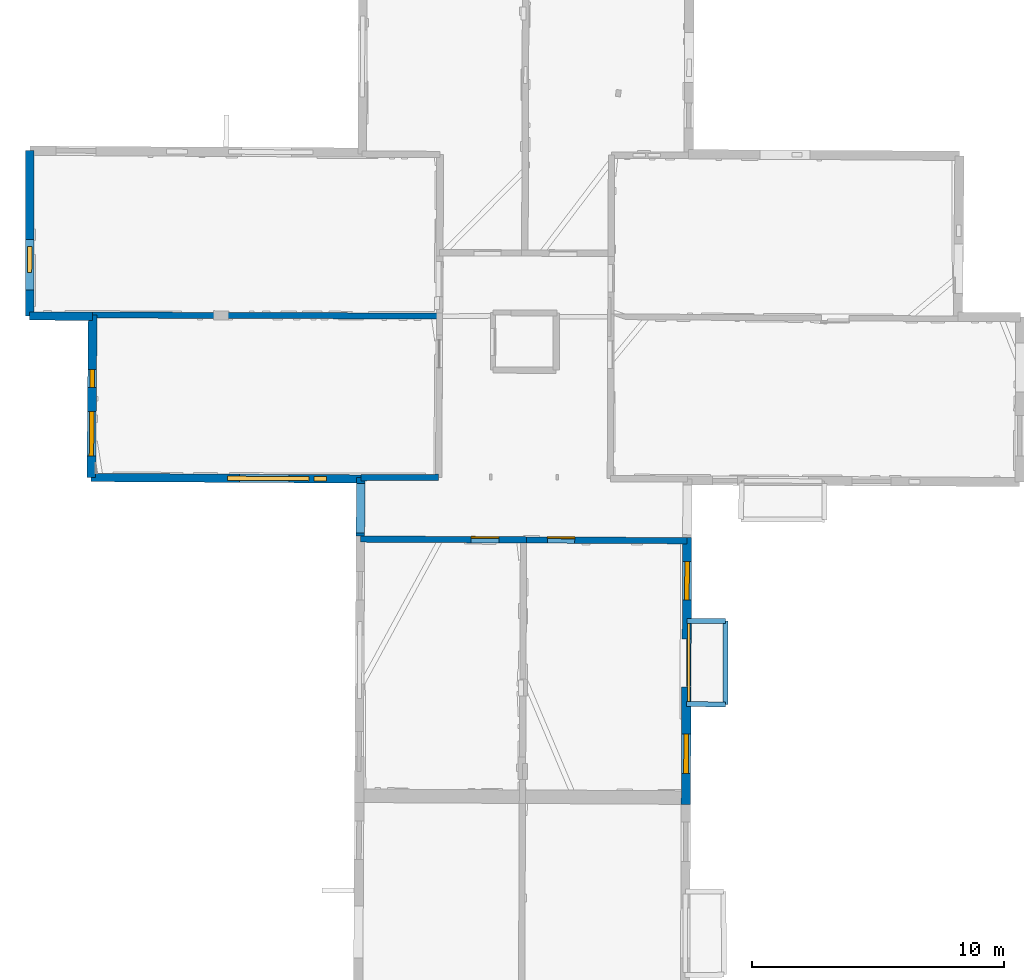
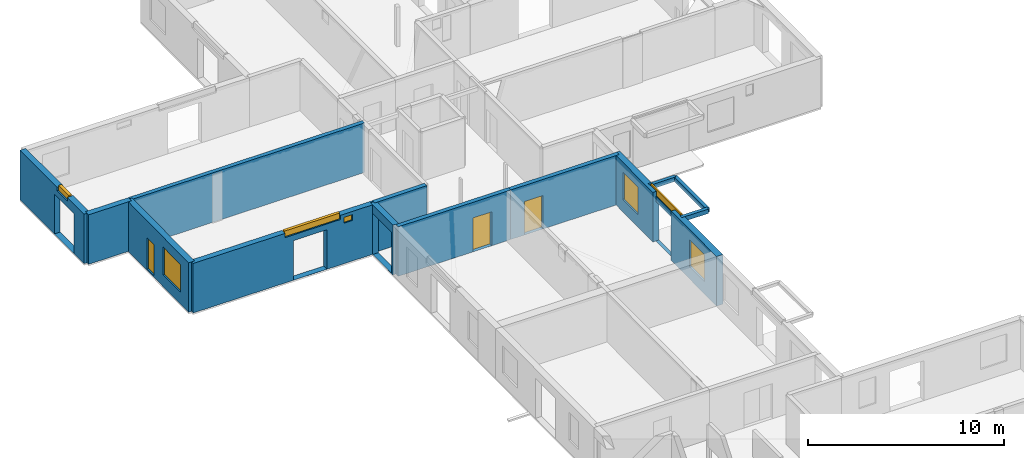
# One storey, part 7 of 15: 15 walls, 8 windows, 2 doors, 14 openings.
"""IFC2X3 building model written with IfcOpenShell, lengths in metres."""

import ifcopenshell
import ifcopenshell.guid

model = None  # the IFC model being written
_history = None  # IfcOwnerHistory: only IFC2X3 demands one
_inside = {}  # id of a spatial element -> (the spatial element, [elements in it])
_under = {}  # id of a project, library or spatial element -> (it, [spatial elements below it])
_declared = {}  # id of a project -> (the project, [libraries it declares])
_typed = {}  # id of a type object -> (the type object, [elements of that type])
_made_of = {}  # id of a material, layer set ... -> (it, [elements and type objects made of it])


def new_model(schema):
    """Start an empty IFC model of exactly this schema.

    Asked for "IFC4X3", IfcOpenShell would pick the latest addendum, in which some entities
    have other attributes; the version numbers below select the first issue.
    IFC2X3 requires an IfcOwnerHistory on every rooted entity: one is made here for all.
    """
    global model, _history
    if schema == "IFC4X3":
        model = ifcopenshell.file(schema_version=(4, 3, 0, 0))
    else:
        model = ifcopenshell.file(schema=schema)
    _inside.clear()
    _under.clear()
    _declared.clear()
    _typed.clear()
    _made_of.clear()
    _history = None
    if model.schema == "IFC2X3":
        org = make("IfcOrganization", Name="unknown")
        user = make(
            "IfcPersonAndOrganization",
            ThePerson=make("IfcPerson", FamilyName="unknown"),
            TheOrganization=org,
        )
        app = make(
            "IfcApplication",
            ApplicationDeveloper=org,
            Version="unknown",
            ApplicationFullName="unknown",
            ApplicationIdentifier="unknown",
        )
        _history = make(
            "IfcOwnerHistory",
            OwningUser=user,
            OwningApplication=app,
            ChangeAction="ADDED",
            CreationDate=0,
        )
    return model


def make(cls, **values):
    """One entity of the class cls with the attributes given. An attribute that is None is left unset."""
    return model.create_entity(
        cls, **{name: value for name, value in values.items() if value is not None}
    )


def entity(cls, *values):
    """Any entity or typed value of the class cls, its attributes in the order of the schema. None: left unset."""
    e = model.create_entity(cls)
    for i, value in enumerate(values):
        if value is not None:
            e[i] = value
    return e


def rooted(cls, **values):
    """An entity with a GlobalId (a new one), such as an element, a storey or a relation."""
    return make(cls, GlobalId=ifcopenshell.guid.new(), OwnerHistory=_history, **values)


def si_unit(unit_type, name, prefix=None):
    """IfcSIUnit, for example si_unit("LENGTHUNIT", "METRE", prefix="MILLI")."""
    return make("IfcSIUnit", UnitType=unit_type, Prefix=prefix, Name=name)


def converted_unit(unit_type, name, factor, base, dimensions=None, offset=None):
    """IfcConversionBasedUnit, such as the inch: factor (a typed value) times the base unit."""
    return make(
        "IfcConversionBasedUnit"
        if offset is None
        else "IfcConversionBasedUnitWithOffset",
        ConversionOffset=offset,
        Dimensions=None
        if dimensions is None
        else entity("IfcDimensionalExponents", *dimensions),
        UnitType=unit_type,
        Name=name,
        ConversionFactor=make(
            "IfcMeasureWithUnit", ValueComponent=factor, UnitComponent=base
        ),
    )


def derived_unit(unit_type, elements):
    """IfcDerivedUnit: a product of units, each with its exponent."""
    return make(
        "IfcDerivedUnit",
        Elements=[
            make("IfcDerivedUnitElement", Unit=unit, Exponent=power)
            for unit, power in elements
        ],
        UnitType=unit_type,
    )


def assignment(units):
    """IfcUnitAssignment: the units of a project."""
    return None if units is None else make("IfcUnitAssignment", Units=units)


def point(xyz):
    """IfcCartesianPoint."""
    return None if xyz is None else make("IfcCartesianPoint", Coordinates=xyz)


def direction(xyz):
    """IfcDirection."""
    return None if xyz is None else make("IfcDirection", DirectionRatios=xyz)


def frame(location, z_axis=None, x_axis=None):
    """IfcAxis2Placement3D, a coordinate frame: its origin and axes. An axis left out is left unset."""
    return make(
        "IfcAxis2Placement3D",
        Location=point(location),
        Axis=direction(z_axis),
        RefDirection=direction(x_axis),
    )


def frame_2d(location, x_axis=None):
    """IfcAxis2Placement2D, a coordinate frame in the plane: its origin and x axis."""
    return make(
        "IfcAxis2Placement2D", Location=point(location), RefDirection=direction(x_axis)
    )


def origin():
    """The frame at (0, 0, 0) with its axes left unset."""
    return frame((0.0, 0.0, 0.0))


def origin_2d_with_axis():
    """The frame at (0, 0) in the plane with the x axis (1, 0) written out."""
    return frame_2d((0.0, 0.0), x_axis=(1.0, 0.0))


def place(relative_to, where):
    """IfcLocalPlacement: puts the frame where relative to a parent placement (None: the world)."""
    return make(
        "IfcLocalPlacement", PlacementRelTo=relative_to, RelativePlacement=where
    )


def context(
    kind, dimensions, precision=None, world=None, true_north=None, identifier=None
):
    """IfcGeometricRepresentationContext, for example the 3D "Model" context."""
    return make(
        "IfcGeometricRepresentationContext",
        ContextIdentifier=identifier,
        ContextType=kind,
        CoordinateSpaceDimension=dimensions,
        Precision=precision,
        WorldCoordinateSystem=world,
        TrueNorth=true_north,
    )


def subcontext(parent, identifier, kind, view, scale=None):
    """IfcGeometricRepresentationSubContext, for example "Body" below "Model"."""
    return make(
        "IfcGeometricRepresentationSubContext",
        ContextIdentifier=identifier,
        ContextType=kind,
        ParentContext=parent,
        TargetScale=scale,
        TargetView=view,
    )


def project(units=None, contexts=None):
    """IfcProject with its units and contexts."""
    return rooted(
        "IfcProject",
        Name="project",
        RepresentationContexts=contexts,
        UnitsInContext=assignment(units),
    )


def spatial(cls, under=None, at=None, **own):
    """A site, building, storey or space (cls), placed at a placement, below another one or the project."""
    s = rooted(cls, ObjectPlacement=at, **own)
    if under is not None:
        _under.setdefault(under.id(), (under, []))[1].append(s)
    return s


def polyline(points):
    """IfcPolyline through the points."""
    return make("IfcPolyline", Points=[point(p) for p in points])


def profile(cls, at=None, kind="AREA", **sizes):
    """A parametric profile (cls). Its sizes go by their IFC names, for example OverallWidth=200.0."""
    return make(cls, ProfileType=kind, Position=at, **sizes)


def rectangle(**sizes):
    """IfcRectangleProfileDef."""
    return profile("IfcRectangleProfileDef", **sizes)


def outline(outer, holes=None, kind="AREA"):
    """IfcArbitraryClosedProfileDef: a profile drawn as a closed curve; with holes, ...WithVoids."""
    if holes is None:
        return make("IfcArbitraryClosedProfileDef", ProfileType=kind, OuterCurve=outer)
    return make(
        "IfcArbitraryProfileDefWithVoids",
        ProfileType=kind,
        OuterCurve=outer,
        InnerCurves=holes,
    )


def extrude(swept, where, along, depth):
    """IfcExtrudedAreaSolid: the profile swept, set in the frame where, extruded along a direction by depth."""
    return make(
        "IfcExtrudedAreaSolid",
        SweptArea=swept,
        Position=where,
        ExtrudedDirection=direction(along),
        Depth=depth,
    )


def shape(context_of_items, identifier, shape_type, items):
    """IfcShapeRepresentation: the items that make up one representation, for example the "Body"."""
    return make(
        "IfcShapeRepresentation",
        ContextOfItems=context_of_items,
        RepresentationIdentifier=identifier,
        RepresentationType=shape_type,
        Items=items,
    )


def source(mapping_origin, context_of_items, identifier, shape_type, items):
    """IfcRepresentationMap: a shape defined once, which mapped items show again and again."""
    return make(
        "IfcRepresentationMap",
        MappingOrigin=mapping_origin,
        MappedRepresentation=shape(context_of_items, identifier, shape_type, items),
    )


def transform(
    local_origin,
    x_axis=None,
    y_axis=None,
    z_axis=None,
    scale=None,
    scale2=None,
    scale3=None,
    uniform=True,
):
    """IfcCartesianTransformationOperator3D, or its non-uniform kind. x_axis, y_axis, z_axis: its Axis1, 2, 3."""
    if uniform:
        return make(
            "IfcCartesianTransformationOperator3D",
            Axis1=direction(x_axis),
            Axis2=direction(y_axis),
            LocalOrigin=point(local_origin),
            Scale=scale,
            Axis3=direction(z_axis),
        )
    return make(
        "IfcCartesianTransformationOperator3DnonUniform",
        Axis1=direction(x_axis),
        Axis2=direction(y_axis),
        LocalOrigin=point(local_origin),
        Scale=scale,
        Axis3=direction(z_axis),
        Scale2=scale2,
        Scale3=scale3,
    )


def mapped(mapping_source, mapping_target):
    """IfcMappedItem: shows the shape of a source again, moved by a transform."""
    return make(
        "IfcMappedItem", MappingSource=mapping_source, MappingTarget=mapping_target
    )


def material(Name=None, Category=None):
    """IfcMaterial."""
    return make("IfcMaterial", Name=Name, Category=Category)


def layer(
    of_material, thickness, ventilated=None, Name=None, Category=None, Priority=None
):
    """IfcMaterialLayer: one layer of a wall or slab, of a material (None: an air gap)."""
    return make(
        "IfcMaterialLayer",
        Material=of_material,
        LayerThickness=thickness,
        IsVentilated=ventilated,
        Name=Name,
        Category=Category,
        Priority=Priority,
    )


def layer_set(layers, Name=None):
    """IfcMaterialLayerSet."""
    return make("IfcMaterialLayerSet", MaterialLayers=layers, LayerSetName=Name)


def layer_usage(for_layer_set, set_direction, sense, offset, extent=None):
    """IfcMaterialLayerSetUsage: how a layer set lies in its element."""
    return make(
        "IfcMaterialLayerSetUsage",
        ForLayerSet=for_layer_set,
        LayerSetDirection=set_direction,
        DirectionSense=sense,
        OffsetFromReferenceLine=offset,
        ReferenceExtent=extent,
    )


def made_of(thing, what):
    """Note that an element or type object is made of a material, layer set ...; save() writes the relation."""
    if what is not None:
        _made_of.setdefault(what.id(), (what, []))[1].append(thing)
    return thing


def type_object(cls, material=None, **own):
    """A type object (cls), such as IfcWallType, which elements share."""
    return made_of(rooted(cls, **own), material)


def type_shapes(of_type, sources):
    """Give a type object the sources (RepresentationMaps) that its elements show as mapped items."""
    of_type.RepresentationMaps = sources


def element(
    cls,
    number,
    at=None,
    inside=None,
    cuts=None,
    type_object=None,
    material=None,
    context=None,
    identifier="Body",
    shape_type=None,
    held_by="IfcProductDefinitionShape",
    body=None,
    shapes=None,
    **own,
):
    """One element of the class cls, such as IfcWall. Its Tag is "e" and its number.

    at: its placement. inside: the storey or other place that contains it. cuts: it is an
    opening in that element (IfcRelVoidsElement). A single representation is given by context,
    identifier, shape_type and body (its items); several are given by shapes. held_by: the class
    of the entity that holds the representations. save() writes the other relations.
    """
    e = rooted(cls, Tag="e%d" % number, ObjectPlacement=at, **own)
    if body is not None:
        shapes = [shape(context, identifier, shape_type, body)]
    if shapes is not None:
        e.Representation = make(held_by, Representations=shapes)
    if inside is not None:
        _inside.setdefault(inside.id(), (inside, []))[1].append(e)
    if cuts is not None:
        rooted(
            "IfcRelVoidsElement", RelatingBuildingElement=cuts, RelatedOpeningElement=e
        )
    if type_object is not None:
        _typed.setdefault(type_object.id(), (type_object, []))[1].append(e)
    return made_of(e, material)


def fill(opening, filler):
    """IfcRelFillsElement: the door or window that sits in an opening."""
    return rooted(
        "IfcRelFillsElement",
        RelatingOpeningElement=opening,
        RelatedBuildingElement=filler,
    )


def aggregate(whole, parts):
    """IfcRelAggregates: a whole, such as a stair, and the parts it consists of."""
    return rooted("IfcRelAggregates", RelatingObject=whole, RelatedObjects=parts)


def save(model, path):
    """Write the relations noted so far, then the file.

    IfcRelAggregates (storeys below a building ...), IfcRelContainedInSpatialStructure (elements
    in a storey), IfcRelDefinesByType, IfcRelAssociatesMaterial and IfcRelDeclares: one each for
    every whole, place, type object, material and project.
    """
    for whole, parts in _under.values():
        aggregate(whole, parts)
    for where, things in _inside.values():
        rooted(
            "IfcRelContainedInSpatialStructure",
            RelatedElements=things,
            RelatingStructure=where,
        )
    for kind, things in _typed.values():
        rooted("IfcRelDefinesByType", RelatedObjects=things, RelatingType=kind)
    for what, things in _made_of.values():
        rooted("IfcRelAssociatesMaterial", RelatedObjects=things, RelatingMaterial=what)
    for by, libraries in _declared.values():
        rooted("IfcRelDeclares", RelatingContext=by, RelatedDefinitions=libraries)
    model.write(path)


model = new_model("IFC2X3")

# Units and contexts
model_context = context("Model", 3, precision=1e-05, world=origin(), true_north=direction((0.0, 1.0)))
body_context = subcontext(model_context, "Body", "Model", "MODEL_VIEW")
ifc_project = project(units=[si_unit("LENGTHUNIT", "METRE"), si_unit("AREAUNIT", "SQUARE_METRE"), si_unit("VOLUMEUNIT", "CUBIC_METRE"), converted_unit("PLANEANGLEUNIT", "DEGREE", entity("IfcRatioMeasure", 0.0174532925199433), si_unit("PLANEANGLEUNIT", "RADIAN"), dimensions=[0, 0, 0, 0, 0, 0, 0]), si_unit("MASSUNIT", "GRAM", prefix="KILO"), derived_unit("MASSDENSITYUNIT", [(si_unit("MASSUNIT", "GRAM", prefix="KILO"), 1), (si_unit("LENGTHUNIT", "METRE"), -3)]), derived_unit("MOMENTOFINERTIAUNIT", [(si_unit("LENGTHUNIT", "METRE"), 4)]), si_unit("TIMEUNIT", "SECOND"), si_unit("FREQUENCYUNIT", "HERTZ"), si_unit("THERMODYNAMICTEMPERATUREUNIT", "DEGREE_CELSIUS"), derived_unit("THERMALTRANSMITTANCEUNIT", [(si_unit("MASSUNIT", "GRAM", prefix="KILO"), 1), (si_unit("THERMODYNAMICTEMPERATUREUNIT", "KELVIN"), -1), (si_unit("TIMEUNIT", "SECOND"), -3)]), derived_unit("VOLUMETRICFLOWRATEUNIT", [(si_unit("LENGTHUNIT", "METRE"), 3), (si_unit("TIMEUNIT", "SECOND"), -1)]), si_unit("ELECTRICCURRENTUNIT", "AMPERE"), si_unit("ELECTRICVOLTAGEUNIT", "VOLT"), si_unit("POWERUNIT", "WATT"), si_unit("FORCEUNIT", "NEWTON", prefix="KILO"), si_unit("ILLUMINANCEUNIT", "LUX"), si_unit("LUMINOUSFLUXUNIT", "LUMEN"), si_unit("LUMINOUSINTENSITYUNIT", "CANDELA"), derived_unit("USERDEFINED", [(si_unit("MASSUNIT", "GRAM", prefix="KILO"), -1), (si_unit("LENGTHUNIT", "METRE"), -2), (si_unit("TIMEUNIT", "SECOND"), 3), (si_unit("LUMINOUSFLUXUNIT", "LUMEN"), 1)]), derived_unit("LINEARVELOCITYUNIT", [(si_unit("LENGTHUNIT", "METRE"), 1), (si_unit("TIMEUNIT", "SECOND"), -1)]), si_unit("PRESSUREUNIT", "PASCAL"), derived_unit("USERDEFINED", [(si_unit("LENGTHUNIT", "METRE"), -2), (si_unit("MASSUNIT", "GRAM", prefix="KILO"), 1), (si_unit("TIMEUNIT", "SECOND"), -2)]), derived_unit("LINEARFORCEUNIT", [(si_unit("MASSUNIT", "GRAM", prefix="KILO"), 1), (si_unit("LENGTHUNIT", "METRE"), 1), (si_unit("TIMEUNIT", "SECOND"), -2), (si_unit("LENGTHUNIT", "METRE"), -1)]), derived_unit("PLANARFORCEUNIT", [(si_unit("MASSUNIT", "GRAM", prefix="KILO"), 1), (si_unit("LENGTHUNIT", "METRE"), 1), (si_unit("TIMEUNIT", "SECOND"), -2), (si_unit("LENGTHUNIT", "METRE"), -2)])], contexts=[model_context])

# Site, building, storey
placement_1 = place(None, origin())
site = spatial("IfcSite", under=ifc_project, at=placement_1, CompositionType="ELEMENT")
building = spatial("IfcBuilding", under=site, at=placement_1, CompositionType="ELEMENT")
storey_placement = place(placement_1, frame((0.0, 0.0, 2.3807327747345)))
storey = spatial("IfcBuildingStorey", under=building, at=storey_placement, Name="Level 2", CompositionType="ELEMENT", Elevation=2.3807327747345)

# Wall
ifc_material_1 = material(Name="Default wall")
ifc_layer_1 = layer(ifc_material_1, 0.25)
ifc_layer_set_1 = layer_set([ifc_layer_1], Name="wall_thickness_0.2500")
ifc_layer_usage_1 = layer_usage(ifc_layer_set_1, "AXIS2", "POSITIVE", -0.125)
wall_type_1 = type_object("IfcWallType", Name="wall_thickness_0.2500", PredefinedType="STANDARD", material=ifc_layer_set_1)
wall_1_placement = place(storey_placement, frame((-0.148051740136855, 51.2275461163423, 0.0), z_axis=(0.0, 0.0, 1.0), x_axis=(0.999995392758805, 0.00303553309380172, 0.0)))
element("IfcWallStandardCase", 1, at=wall_1_placement, inside=storey, type_object=wall_type_1, material=ifc_layer_usage_1, Name="Wall:709", ObjectType="Wall", context=body_context, shape_type="SweptSolid", body=[
    extrude(outline(polyline([(3.09394902896823, -0.125), (3.09394902896823, 0.125), (0.0, 0.125), (0.0, -0.125), (3.09394902896823, -0.125)])), origin(), (0.0, 0.0, 1.0), 3.08589615821838),
])

# Wall, opening, door
wall_2_placement = place(storey_placement, frame((-0.162484600714086, 48.7866531647562, 0.0), z_axis=(0.0, 0.0, 1.0), x_axis=(0.999987572034847, -0.00498555672428719, 0.0)))
wall_2 = element("IfcWallStandardCase", 2, at=wall_2_placement, inside=storey, type_object=wall_type_1, material=ifc_layer_usage_1, Name="Wall:801", ObjectType="Wall", context=body_context, shape_type="SweptSolid", body=[
    extrude(outline(polyline([(6.60324196934107, -0.125), (6.60324196934107, 0.125), (0.0, 0.125), (0.0, -0.125), (6.60324196934107, -0.125)])), origin(), (0.0, 0.0, 1.0), 3.08589615821838),
])
opening_1_placement = place(wall_2_placement, frame((4.39437935703402, -0.125, 0.00526785850524902)))
opening_1 = element("IfcOpeningElement", 3, at=opening_1_placement, cuts=wall_2, Name="Opening : 1110 x 2110 : 512", ObjectType="Opening", context=body_context, shape_type="SweptSolid", body=[
    extrude(rectangle(XDim=1.11, YDim=2.11, at=frame_2d((1.055, 0.555), x_axis=(0.0, 1.0))), frame((0.0, 0.0, 0.0), z_axis=(0.0, 1.0, 0.0), x_axis=(0.0, 0.0, 1.0)), (0.0, 0.0, 1.0), 0.25),
])
ifc_material_2 = material(Name="Door Panel")
door_style_1 = type_object("IfcDoorStyle", Name="Door : 1110 x 2110mm", ConstructionType="NOTDEFINED", OperationType="SINGLE_SWING_RIGHT", ParameterTakesPrecedence=False, Sizeable=False, material=ifc_material_2)
shared_shape_1 = source(origin(), body_context, "Body", "SweptSolid", [
    extrude(rectangle(XDim=0.0625, YDim=1.11, at=origin_2d_with_axis()), frame((0.555, 0.21875, 0.0), z_axis=(0.0, 0.0, 1.0), x_axis=(0.0, 1.0, 0.0)), (0.0, 0.0, 1.0), 2.11),
])
type_shapes(door_style_1, [shared_shape_1])
door_1_placement = place(opening_1_placement, origin())
door_1 = element("IfcDoor", 4, at=door_1_placement, inside=storey, type_object=door_style_1, Name="Door : 1110 x 2110mm : 94", ObjectType="Door : 1110 x 2110mm", OverallHeight=2.11, OverallWidth=1.11, context=body_context, shape_type="MappedRepresentation", body=[
    mapped(shared_shape_1, transform((0.0, 0.0, 0.0), scale=1.0)),
])
fill(opening_1, door_1)

wall_3_placement = place(storey_placement, frame((6.44067530376589, 48.7537323273539, 0.0), z_axis=(0.0, 0.0, 1.0), x_axis=(0.999987571536951, -0.00498565658975352, 0.0)))
wall_3 = element("IfcWallStandardCase", 5, at=wall_3_placement, inside=storey, type_object=wall_type_1, material=ifc_layer_usage_1, Name="Wall:802", ObjectType="Wall", context=body_context, shape_type="SweptSolid", body=[
    extrude(outline(polyline([(6.37662992614789, -0.125), (6.37662992614789, 0.125), (0.0, 0.125), (0.0, -0.125), (6.37662992614789, -0.125)])), origin(), (0.0, 0.0, 1.0), 3.08589615821838),
])
opening_2_placement = place(wall_3_placement, frame((0.826137280033329, -0.125, 0.00526785850524902)))
opening_2 = element("IfcOpeningElement", 6, at=opening_2_placement, cuts=wall_3, Name="Opening : 1085 x 2080 : 513", ObjectType="Opening", context=body_context, shape_type="SweptSolid", body=[
    extrude(rectangle(XDim=1.085, YDim=2.08, at=frame_2d((1.04, 0.5425), x_axis=(0.0, 1.0))), frame((0.0, 0.0, 0.0), z_axis=(0.0, 1.0, 0.0), x_axis=(0.0, 0.0, 1.0)), (0.0, 0.0, 1.0), 0.25),
])
door_style_2 = type_object("IfcDoorStyle", Name="Door : 1085 x 2080mm", ConstructionType="NOTDEFINED", OperationType="SINGLE_SWING_RIGHT", ParameterTakesPrecedence=False, Sizeable=False, material=ifc_material_2)
shared_shape_2 = source(origin(), body_context, "Body", "SweptSolid", [
    extrude(rectangle(XDim=0.0625, YDim=1.085, at=origin_2d_with_axis()), frame((0.5425, 0.21875, 0.0), z_axis=(0.0, 0.0, 1.0), x_axis=(0.0, 1.0, 0.0)), (0.0, 0.0, 1.0), 2.08),
])
type_shapes(door_style_2, [shared_shape_2])
door_2_placement = place(opening_2_placement, origin())
door_2 = element("IfcDoor", 7, at=door_2_placement, inside=storey, type_object=door_style_2, Name="Door : 1085 x 2080mm : 95", ObjectType="Door : 1085 x 2080mm", OverallHeight=2.08, OverallWidth=1.085, context=body_context, shape_type="MappedRepresentation", body=[
    mapped(shared_shape_2, transform((0.0, 0.0, 0.0), scale=1.0)),
])
fill(opening_2, door_2)

# Wall, openings, windows
ifc_layer_2 = layer(ifc_material_1, 0.330000013113022)
ifc_layer_set_2 = layer_set([ifc_layer_2], Name="wall_thickness_0.3300")
ifc_layer_usage_2 = layer_usage(ifc_layer_set_2, "AXIS2", "POSITIVE", -0.165000006556511)
wall_type_2 = type_object("IfcWallType", Name="wall_thickness_0.3300", PredefinedType="STANDARD", material=ifc_layer_set_2)
wall_4_placement = place(storey_placement, frame((-10.8537634339708, 51.2337306651839, 0.0), z_axis=(0.0, 0.0, 1.0), x_axis=(0.999984504576735, -0.0055669207307725, 0.0)))
wall_4 = element("IfcWallStandardCase", 8, at=wall_4_placement, inside=storey, type_object=wall_type_2, material=ifc_layer_usage_2, Name="Wall:705", ObjectType="Wall", context=body_context, shape_type="SweptSolid", body=[
    extrude(outline(polyline([(10.7055620626, -0.165000006556511), (10.7055620626, 0.165000006556511), (0.0, 0.165000006556511), (0.0, -0.165000006556511), (10.7055620626, -0.165000006556511)])), origin(), (0.0, 0.0, 1.0), 3.08589615821838),
])
opening_3_placement = place(wall_4_placement, frame((5.89218545140347, -0.165000006556511, 0.00526785850524902)))
element("IfcOpeningElement", 9, at=opening_3_placement, cuts=wall_4, Name="Opening : 1960 x 2460 : 445", ObjectType="Opening", context=body_context, shape_type="SweptSolid", body=[
    extrude(rectangle(XDim=1.96, YDim=2.46, at=frame_2d((1.23, 0.98), x_axis=(0.0, 1.0))), frame((0.0, 0.0, 0.0), z_axis=(0.0, 1.0, 0.0), x_axis=(0.0, 0.0, 1.0)), (0.0, 0.0, 1.0), 0.330000013113022),
])
opening_4_placement = place(wall_4_placement, frame((5.40718544851281, -0.165000006556511, 2.82526755332947)))
opening_4 = element("IfcOpeningElement", 10, at=opening_4_placement, cuts=wall_4, Name="Opening : 3250 x 350 : 446", ObjectType="Opening", context=body_context, shape_type="SweptSolid", body=[
    extrude(rectangle(XDim=3.25, YDim=0.35, at=frame_2d((0.175, 1.625), x_axis=(0.0, 1.0))), frame((0.0, 0.0, 0.0), z_axis=(0.0, 1.0, 0.0), x_axis=(0.0, 0.0, 1.0)), (0.0, 0.0, 1.0), 0.330000013113022),
])
opening_5_placement = place(wall_4_placement, frame((8.84740951184259, -0.165000006556511, 2.52126717567444)))
opening_5 = element("IfcOpeningElement", 11, at=opening_5_placement, cuts=wall_4, Name="Opening : 505 x 365 : 447", ObjectType="Opening", context=body_context, shape_type="SweptSolid", body=[
    extrude(rectangle(XDim=0.505, YDim=0.365, at=frame_2d((0.1825, 0.2525), x_axis=(0.0, 1.0))), frame((0.0, 0.0, 0.0), z_axis=(0.0, 1.0, 0.0), x_axis=(0.0, 0.0, 1.0)), (0.0, 0.0, 1.0), 0.330000013113022),
])
ifc_material_3 = material(Name="Window Default")
window_style_1 = type_object("IfcWindowStyle", Name="Window : 3250 x 350mm", ConstructionType="NOTDEFINED", OperationType="NOTDEFINED", ParameterTakesPrecedence=False, Sizeable=False, material=ifc_material_3)
shared_shape_3 = source(origin(), body_context, "Body", "SweptSolid", [
    extrude(rectangle(XDim=0.165000006556511, YDim=3.25, at=origin_2d_with_axis()), frame((1.625, 0.165000006556511, 0.0), z_axis=(0.0, 0.0, 1.0), x_axis=(0.0, 1.0, 0.0)), (0.0, 0.0, 1.0), 0.35),
])
type_shapes(window_style_1, [shared_shape_3])
window_1_placement = place(opening_4_placement, origin())
window_1 = element("IfcWindow", 12, at=window_1_placement, inside=storey, type_object=window_style_1, Name="Window : 3250 x 350mm : 241", ObjectType="Window : 3250 x 350mm", OverallHeight=0.35, OverallWidth=3.25, context=body_context, shape_type="MappedRepresentation", body=[
    mapped(shared_shape_3, transform((0.0, 0.0, 0.0), scale=1.0)),
])
fill(opening_4, window_1)
window_style_2 = type_object("IfcWindowStyle", Name="Window : 505 x 365mm", ConstructionType="NOTDEFINED", OperationType="NOTDEFINED", ParameterTakesPrecedence=False, Sizeable=False, material=ifc_material_3)
shared_shape_4 = source(origin(), body_context, "Body", "SweptSolid", [
    extrude(rectangle(XDim=0.165000006556511, YDim=0.505, at=origin_2d_with_axis()), frame((0.2525, 0.165000006556511, 0.0), z_axis=(0.0, 0.0, 1.0), x_axis=(0.0, 1.0, 0.0)), (0.0, 0.0, 1.0), 0.365),
])
type_shapes(window_style_2, [shared_shape_4])
window_2_placement = place(opening_5_placement, origin())
window_2 = element("IfcWindow", 13, at=window_2_placement, inside=storey, type_object=window_style_2, Name="Window : 505 x 365mm : 242", ObjectType="Window : 505 x 365mm", OverallHeight=0.365, OverallWidth=0.505, context=body_context, shape_type="MappedRepresentation", body=[
    mapped(shared_shape_4, transform((0.0, 0.0, 0.0), scale=1.0)),
])
fill(opening_5, window_2)

# Wall
wall_5_placement = place(storey_placement, frame((-13.3039405828259, 57.6493835989592, 0.0), z_axis=(0.0, 0.0, 1.0), x_axis=(0.999982718334924, -0.00587903321092661, 0.0)))
element("IfcWallStandardCase", 14, at=wall_5_placement, inside=storey, type_object=wall_type_2, material=ifc_layer_usage_2, Name="Wall:757", ObjectType="Wall", context=body_context, shape_type="SweptSolid", body=[
    extrude(outline(polyline([(2.50851102550275, -0.165000006556511), (2.50851102550275, 0.165000006556511), (0.0, 0.165000006556511), (0.0, -0.165000006556511), (2.50851102550275, -0.165000006556511)])), origin(), (0.0, 0.0, 1.0), 3.08589615821838),
])

# Wall, openings, windows
ifc_layer_3 = layer(ifc_material_1, 0.349999994039536)
ifc_layer_set_3 = layer_set([ifc_layer_3], Name="wall_thickness_0.3500")
ifc_layer_usage_3 = layer_usage(ifc_layer_set_3, "AXIS2", "POSITIVE", -0.174999997019768)
wall_type_3 = type_object("IfcWallType", Name="wall_thickness_0.3500", PredefinedType="STANDARD", material=ifc_layer_set_3)
wall_6_placement = place(storey_placement, frame((-10.7950113411826, 57.6853036298167, 0.0), z_axis=(0.0, 0.0, 1.0), x_axis=(-0.00910639665219656, -0.999958535910371, 0.0)))
wall_6 = element("IfcWallStandardCase", 15, at=wall_6_placement, inside=storey, type_object=wall_type_3, material=ifc_layer_usage_3, Name="Wall:838", ObjectType="Wall", context=body_context, shape_type="SweptSolid", body=[
    extrude(outline(polyline([(6.45183993788235, -0.174999997019768), (6.45183993788235, 0.174999997019768), (0.0, 0.174999997019768), (0.0, -0.174999997019768), (6.45183993788235, -0.174999997019768)])), origin(), (0.0, 0.0, 1.0), 3.08589615821838),
])
opening_6_placement = place(wall_6_placement, frame((3.82831421251605, -0.174999997019768, 0.735267639160156)))
opening_6 = element("IfcOpeningElement", 16, at=opening_6_placement, cuts=wall_6, Name="Opening : 1765 x 1730 : 531", ObjectType="Opening", context=body_context, shape_type="SweptSolid", body=[
    extrude(rectangle(XDim=1.765, YDim=1.73, at=frame_2d((0.865, 0.8825), x_axis=(0.0, 1.0))), frame((0.0, 0.0, 0.0), z_axis=(0.0, 1.0, 0.0), x_axis=(0.0, 0.0, 1.0)), (0.0, 0.0, 1.0), 0.349999994039536),
])
opening_7_placement = place(wall_6_placement, frame((2.16086760168938, -0.174999997019768, 0.0872671604156494)))
opening_7 = element("IfcOpeningElement", 17, at=opening_7_placement, cuts=wall_6, Name="Opening : 720 x 1935 : 532", ObjectType="Opening", context=body_context, shape_type="SweptSolid", body=[
    extrude(rectangle(XDim=0.72, YDim=1.935, at=frame_2d((0.9675, 0.36), x_axis=(0.0, 1.0))), frame((0.0, 0.0, 0.0), z_axis=(0.0, 1.0, 0.0), x_axis=(0.0, 0.0, 1.0)), (0.0, 0.0, 1.0), 0.349999994039536),
])
window_style_3 = type_object("IfcWindowStyle", Name="Window : 1765 x 1730mm", ConstructionType="NOTDEFINED", OperationType="NOTDEFINED", ParameterTakesPrecedence=False, Sizeable=False, material=ifc_material_3)
shared_shape_5 = source(origin(), body_context, "Body", "SweptSolid", [
    extrude(rectangle(XDim=0.174999997019768, YDim=1.765, at=origin_2d_with_axis()), frame((0.8825, 0.174999997019768, 0.0), z_axis=(0.0, 0.0, 1.0), x_axis=(0.0, 1.0, 0.0)), (0.0, 0.0, 1.0), 1.73),
])
type_shapes(window_style_3, [shared_shape_5])
window_3_placement = place(opening_6_placement, origin())
window_3 = element("IfcWindow", 18, at=window_3_placement, inside=storey, type_object=window_style_3, Name="Window : 1765 x 1730mm : 284", ObjectType="Window : 1765 x 1730mm", OverallHeight=1.73, OverallWidth=1.765, context=body_context, shape_type="MappedRepresentation", body=[
    mapped(shared_shape_5, transform((0.0, 0.0, 0.0), scale=1.0)),
])
fill(opening_6, window_3)
window_style_4 = type_object("IfcWindowStyle", Name="Window : 720 x 1935mm", ConstructionType="NOTDEFINED", OperationType="NOTDEFINED", ParameterTakesPrecedence=False, Sizeable=False, material=ifc_material_3)
shared_shape_6 = source(origin(), body_context, "Body", "SweptSolid", [
    extrude(rectangle(XDim=0.174999997019768, YDim=0.72, at=origin_2d_with_axis()), frame((0.36, 0.174999997019768, 0.0), z_axis=(0.0, 0.0, 1.0), x_axis=(0.0, 1.0, 0.0)), (0.0, 0.0, 1.0), 1.935),
])
type_shapes(window_style_4, [shared_shape_6])
window_4_placement = place(opening_7_placement, origin())
window_4 = element("IfcWindow", 19, at=window_4_placement, inside=storey, type_object=window_style_4, Name="Window : 720 x 1935mm : 285", ObjectType="Window : 720 x 1935mm", OverallHeight=1.935, OverallWidth=0.72, context=body_context, shape_type="MappedRepresentation", body=[
    mapped(shared_shape_6, transform((0.0, 0.0, 0.0), scale=1.0)),
])
fill(opening_7, window_4)

# Walls
ifc_layer_4 = layer(ifc_material_1, 0.2)
ifc_layer_set_4 = layer_set([ifc_layer_4], Name="wall_thickness_0.2000")
ifc_layer_usage_4 = layer_usage(ifc_layer_set_4, "AXIS2", "POSITIVE", -0.1)
wall_type_4 = type_object("IfcWallType", Name="wall_thickness_0.2000", PredefinedType="STANDARD", material=ifc_layer_set_4)
placement_2 = place(placement_1, frame((0.0, 0.0, 5.19400024414062)))
wall_7_placement = place(placement_2, frame((14.3439927963247, 45.532805565065, 0.0), z_axis=(0.0, 0.0, 1.0), x_axis=(-0.000427831556208202, -0.999999908480076, 0.0)))
element("IfcWallStandardCase", 20, at=wall_7_placement, inside=storey, type_object=wall_type_4, material=ifc_layer_usage_4, Name="Wall:721", ObjectType="Wall", context=body_context, shape_type="SweptSolid", body=[
    extrude(outline(polyline([(3.31688339071912, -0.1), (3.31688339071912, 0.1), (0.0, 0.1), (0.0, -0.1), (3.31688339071912, -0.1)])), origin(), (0.0, 0.0, 1.0), 0.272628688812256),
])
placement_3 = place(placement_1, frame((0.0, 0.0, 5.19400024414062)))
wall_8_placement = place(placement_3, frame((12.7834679281189, 42.2363428056265, 0.0), z_axis=(0.0, 0.0, 1.0), x_axis=(0.999914241318785, -0.0130961829506972, 0.0)))
element("IfcWallStandardCase", 21, at=wall_8_placement, inside=storey, type_object=wall_type_4, material=ifc_layer_usage_4, Name="Wall:752", ObjectType="Wall", context=body_context, shape_type="SweptSolid", body=[
    extrude(outline(polyline([(1.55923863768286, -0.1), (1.55923863768286, 0.1), (0.0, 0.1), (0.0, -0.1), (1.55923863768286, -0.1)])), origin(), (0.0, 0.0, 1.0), 0.272628688812256),
])
placement_4 = place(placement_1, frame((0.0, 0.0, 5.19400024414062)))
wall_9_placement = place(placement_4, frame((12.8030588866039, 45.5269554537908, 0.0), z_axis=(0.0, 0.0, 1.0), x_axis=(0.999992770654978, 0.00380245154865873, 0.0)))
element("IfcWallStandardCase", 22, at=wall_9_placement, inside=storey, type_object=wall_type_4, material=ifc_layer_usage_4, Name="Wall:794", ObjectType="Wall", context=body_context, shape_type="SweptSolid", body=[
    extrude(outline(polyline([(1.54094665639246, -0.1), (1.54094665639246, 0.1), (0.0, 0.1), (0.0, -0.1), (1.54094665639246, -0.1)])), origin(), (0.0, 0.0, 1.0), 0.272628688812256),
])
ifc_layer_5 = layer(ifc_material_1, 0.239999994635582)
ifc_layer_set_5 = layer_set([ifc_layer_5], Name="wall_thickness_0.2400")
ifc_layer_usage_5 = layer_usage(ifc_layer_set_5, "AXIS2", "POSITIVE", -0.119999997317791)
wall_type_5 = type_object("IfcWallType", Name="wall_thickness_0.2400", PredefinedType="STANDARD", material=ifc_layer_set_5)
wall_10_placement = place(storey_placement, frame((-10.7950110758758, 57.6852983441019, 0.0), z_axis=(0.0, 0.0, 1.0), x_axis=(0.999995918794102, -0.00285699057404342, 0.0)))
element("IfcWallStandardCase", 23, at=wall_10_placement, inside=storey, type_object=wall_type_5, material=ifc_layer_usage_5, Name="Wall:756", ObjectType="Wall", context=body_context, shape_type="SweptSolid", body=[
    extrude(outline(polyline([(13.776750523546, -0.119999997317791), (13.776750523546, 0.119999997317791), (0.0, 0.119999997317791), (0.0, -0.119999997317791), (13.776750523546, -0.119999997317791)])), origin(), (0.0, 0.0, 1.0), 3.08589615821838),
])

# Wall, opening
ifc_layer_6 = layer(ifc_material_1, 0.340000003576279)
ifc_layer_set_6 = layer_set([ifc_layer_6], Name="wall_thickness_0.3400")
ifc_layer_usage_6 = layer_usage(ifc_layer_set_6, "AXIS2", "POSITIVE", -0.170000001788139)
wall_type_6 = type_object("IfcWallType", Name="wall_thickness_0.3400", PredefinedType="STANDARD", material=ifc_layer_set_6)
wall_11_placement = place(storey_placement, frame((-0.148051417451479, 51.22754475746, 0.0), z_axis=(0.0, 0.0, 1.0), x_axis=(-0.00591293698926228, -0.999982518435278, 0.0)))
wall_11 = element("IfcWallStandardCase", 24, at=wall_11_placement, inside=storey, type_object=wall_type_6, material=ifc_layer_usage_6, Name="Wall:783", ObjectType="Wall", context=body_context, shape_type="SweptSolid", body=[
    extrude(outline(polyline([(2.31593175197995, -0.170000001788139), (2.31593175197995, 0.170000001788139), (0.0, 0.170000001788139), (0.0, -0.170000001788139), (2.31593175197995, -0.170000001788139)])), origin(), (0.0, 0.0, 1.0), 3.08589615821838),
])
opening_8_placement = place(wall_11_placement, frame((0.237018913312594, -0.170000001788139, 0.00526785850524902)))
element("IfcOpeningElement", 25, at=opening_8_placement, cuts=wall_11, Name="Opening : 1955 x 2570 : 493", ObjectType="Opening", context=body_context, shape_type="SweptSolid", body=[
    extrude(rectangle(XDim=1.955, YDim=2.57, at=frame_2d((1.285, 0.9775), x_axis=(0.0, 1.0))), frame((0.0, 0.0, 0.0), z_axis=(0.0, 1.0, 0.0), x_axis=(0.0, 0.0, 1.0)), (0.0, 0.0, 1.0), 0.340000003576279),
])

# Wall, openings, window
wall_12_placement = place(storey_placement, frame((-13.2956297122333, 64.2113859185415, 0.0), z_axis=(0.0, 0.0, 1.0), x_axis=(-0.00126671804764541, -0.999999197712372, 0.0)))
wall_12 = element("IfcWallStandardCase", 26, at=wall_12_placement, inside=storey, type_object=wall_type_6, material=ifc_layer_usage_6, Name="Wall:823", ObjectType="Wall", context=body_context, shape_type="SweptSolid", body=[
    extrude(outline(polyline([(6.56201698337504, -0.170000001788139), (6.56201698337504, 0.170000001788139), (0.0, 0.170000001788139), (0.0, -0.170000001788139), (6.56201698337504, -0.170000001788139)])), origin(), (0.0, 0.0, 1.0), 3.08589615821838),
])
opening_9_placement = place(wall_12_placement, frame((3.51710029986283, -0.170000001788139, 0.00526785850524902)))
element("IfcOpeningElement", 27, at=opening_9_placement, cuts=wall_12, Name="Opening : 2015 x 2475 : 523", ObjectType="Opening", context=body_context, shape_type="SweptSolid", body=[
    extrude(rectangle(XDim=2.015, YDim=2.475, at=frame_2d((1.2375, 1.0075), x_axis=(0.0, 1.0))), frame((0.0, 0.0, 0.0), z_axis=(0.0, 1.0, 0.0), x_axis=(0.0, 0.0, 1.0)), (0.0, 0.0, 1.0), 0.340000003576279),
])
opening_10_placement = place(wall_12_placement, frame((3.80709763312586, -0.170000001788139, 2.87026762962341)))
opening_10 = element("IfcOpeningElement", 28, at=opening_10_placement, cuts=wall_12, Name="Opening : 1030 x 305 : 524", ObjectType="Opening", context=body_context, shape_type="SweptSolid", body=[
    extrude(rectangle(XDim=1.03, YDim=0.305, at=frame_2d((0.1525, 0.515), x_axis=(0.0, 1.0))), frame((0.0, 0.0, 0.0), z_axis=(0.0, 1.0, 0.0), x_axis=(0.0, 0.0, 1.0)), (0.0, 0.0, 1.0), 0.340000003576279),
])
window_style_5 = type_object("IfcWindowStyle", Name="Window : 1030 x 305mm", ConstructionType="NOTDEFINED", OperationType="NOTDEFINED", ParameterTakesPrecedence=False, Sizeable=False, material=ifc_material_3)
shared_shape_7 = source(origin(), body_context, "Body", "SweptSolid", [
    extrude(rectangle(XDim=0.170000001788139, YDim=1.03, at=origin_2d_with_axis()), frame((0.515, 0.170000001788139, 0.0), z_axis=(0.0, 0.0, 1.0), x_axis=(0.0, 1.0, 0.0)), (0.0, 0.0, 1.0), 0.305),
])
type_shapes(window_style_5, [shared_shape_7])
window_5_placement = place(opening_10_placement, origin())
window_5 = element("IfcWindow", 29, at=window_5_placement, inside=storey, type_object=window_style_5, Name="Window : 1030 x 305mm : 281", ObjectType="Window : 1030 x 305mm", OverallHeight=0.305, OverallWidth=1.03, context=body_context, shape_type="MappedRepresentation", body=[
    mapped(shared_shape_7, transform((0.0, 0.0, 0.0), scale=1.0)),
])
fill(opening_10, window_5)

# Wall, opening, window
ifc_layer_7 = layer(ifc_material_1, 0.370000004768372)
ifc_layer_set_7 = layer_set([ifc_layer_7], Name="wall_thickness_0.3700")
ifc_layer_usage_7 = layer_usage(ifc_layer_set_7, "AXIS2", "POSITIVE", -0.185000002384186)
wall_type_7 = type_object("IfcWallType", Name="wall_thickness_0.3700", PredefinedType="STANDARD", material=ifc_layer_set_7)
wall_13_placement = place(storey_placement, frame((12.7864650196161, 42.9116364777255, 0.0), z_axis=(0.0, 0.0, 1.0), x_axis=(-0.0044340864934253, -0.999990169390164, 0.0)))
wall_13 = element("IfcWallStandardCase", 30, at=wall_13_placement, inside=storey, type_object=wall_type_7, material=ifc_layer_usage_7, Name="Wall:798", ObjectType="Wall", context=body_context, shape_type="SweptSolid", body=[
    extrude(outline(polyline([(4.66418083099, -0.185000002384186), (4.66418083099, 0.185000002384186), (0.0, 0.185000002384186), (0.0, -0.185000002384186), (4.66418083099, -0.185000002384186)])), origin(), (0.0, 0.0, 1.0), 3.08589615821838),
])
opening_11_placement = place(wall_13_placement, frame((1.86317747156077, -0.185000002384186, 0.775267839431763)))
opening_11 = element("IfcOpeningElement", 31, at=opening_11_placement, cuts=wall_13, Name="Opening : 1575 x 1680 : 506", ObjectType="Opening", context=body_context, shape_type="SweptSolid", body=[
    extrude(rectangle(XDim=1.575, YDim=1.68, at=frame_2d((0.84, 0.7875), x_axis=(0.0, 1.0))), frame((0.0, 0.0, 0.0), z_axis=(0.0, 1.0, 0.0), x_axis=(0.0, 0.0, 1.0)), (0.0, 0.0, 1.0), 0.370000004768372),
])
window_style_6 = type_object("IfcWindowStyle", Name="Window : 1575 x 1680mm", ConstructionType="NOTDEFINED", OperationType="NOTDEFINED", ParameterTakesPrecedence=False, Sizeable=False, material=ifc_material_3)
shared_shape_8 = source(origin(), body_context, "Body", "SweptSolid", [
    extrude(rectangle(XDim=0.185000002384186, YDim=1.575, at=origin_2d_with_axis()), frame((0.7875, 0.185000002384186, 0.0), z_axis=(0.0, 0.0, 1.0), x_axis=(0.0, 1.0, 0.0)), (0.0, 0.0, 1.0), 1.68),
])
type_shapes(window_style_6, [shared_shape_8])
window_6_placement = place(opening_11_placement, origin())
window_6 = element("IfcWindow", 32, at=window_6_placement, inside=storey, type_object=window_style_6, Name="Window : 1575 x 1680mm : 272", ObjectType="Window : 1575 x 1680mm", OverallHeight=1.68, OverallWidth=1.575, context=body_context, shape_type="MappedRepresentation", body=[
    mapped(shared_shape_8, transform((0.0, 0.0, 0.0), scale=1.0)),
])
fill(opening_11, window_6)

ifc_layer_8 = layer(ifc_material_1, 0.360000014305115)
ifc_layer_set_8 = layer_set([ifc_layer_8], Name="wall_thickness_0.3600")
ifc_layer_usage_8 = layer_usage(ifc_layer_set_8, "AXIS2", "POSITIVE", -0.180000007152557)
wall_type_8 = type_object("IfcWallType", Name="wall_thickness_0.3600", PredefinedType="STANDARD", material=ifc_layer_set_8)
wall_14_placement = place(storey_placement, frame((12.8177797011849, 48.8469399473691, 0.0), z_axis=(0.0, 0.0, 1.0), x_axis=(-0.00443431048057596, -0.999990168396951, 0.0)))
wall_14 = element("IfcWallStandardCase", 33, at=wall_14_placement, inside=storey, type_object=wall_type_8, material=ifc_layer_usage_8, Name="Wall:796", ObjectType="Wall", context=body_context, shape_type="SweptSolid", body=[
    extrude(outline(polyline([(4.03680955525249, -0.180000007152557), (4.03680955525249, 0.180000007152557), (0.0, 0.180000007152557), (0.0, -0.180000007152557), (4.03680955525249, -0.180000007152557)])), origin(), (0.0, 0.0, 1.0), 3.08589615821838),
])
opening_12_placement = place(wall_14_placement, frame((0.943563156309579, -0.180000007152557, 0.775267839431763)))
opening_12 = element("IfcOpeningElement", 34, at=opening_12_placement, cuts=wall_14, Name="Opening : 1545 x 1710 : 503", ObjectType="Opening", context=body_context, shape_type="SweptSolid", body=[
    extrude(rectangle(XDim=1.545, YDim=1.71, at=frame_2d((0.855, 0.7725), x_axis=(0.0, 1.0))), frame((0.0, 0.0, 0.0), z_axis=(0.0, 1.0, 0.0), x_axis=(0.0, 0.0, 1.0)), (0.0, 0.0, 1.0), 0.360000014305115),
])
window_style_7 = type_object("IfcWindowStyle", Name="Window : 1545 x 1710mm", ConstructionType="NOTDEFINED", OperationType="NOTDEFINED", ParameterTakesPrecedence=False, Sizeable=False, material=ifc_material_3)
shared_shape_9 = source(origin(), body_context, "Body", "SweptSolid", [
    extrude(rectangle(XDim=0.180000007152557, YDim=1.545, at=origin_2d_with_axis()), frame((0.7725, 0.180000007152557, 0.0), z_axis=(0.0, 0.0, 1.0), x_axis=(0.0, 1.0, 0.0)), (0.0, 0.0, 1.0), 1.71),
])
type_shapes(window_style_7, [shared_shape_9])
window_7_placement = place(opening_12_placement, origin())
window_7 = element("IfcWindow", 35, at=window_7_placement, inside=storey, type_object=window_style_7, Name="Window : 1545 x 1710mm : 270", ObjectType="Window : 1545 x 1710mm", OverallHeight=1.71, OverallWidth=1.545, context=body_context, shape_type="MappedRepresentation", body=[
    mapped(shared_shape_9, transform((0.0, 0.0, 0.0), scale=1.0)),
])
fill(opening_12, window_7)

# Wall, openings, window
ifc_layer_9 = layer(ifc_material_1, 0.189999997615814)
ifc_layer_set_9 = layer_set([ifc_layer_9], Name="wall_thickness_0.1900")
ifc_layer_usage_9 = layer_usage(ifc_layer_set_9, "AXIS2", "POSITIVE", -0.0949999988079071)
wall_type_9 = type_object("IfcWallType", Name="wall_thickness_0.1900", PredefinedType="STANDARD", material=ifc_layer_set_9)
wall_15_placement = place(storey_placement, frame((12.8848812677669, 44.809793123338, 0.0), z_axis=(0.0, 0.0, 1.0), x_axis=(-0.00443347139502903, -0.999990172117401, 0.0)))
wall_15 = element("IfcWallStandardCase", 36, at=wall_15_placement, inside=storey, type_object=wall_type_9, material=ifc_layer_usage_9, Name="Wall:797", ObjectType="Wall", context=body_context, shape_type="SweptSolid", body=[
    extrude(outline(polyline([(1.88671058948931, -0.0949999988079071), (1.88671058948931, 0.0949999988079071), (0.0, 0.0949999988079071), (0.0, -0.0949999988079071), (1.88671058948931, -0.0949999988079071)])), origin(), (0.0, 0.0, 1.0), 3.08589615821838),
])
opening_13_placement = place(wall_15_placement, frame((-0.113248037630963, -0.0949999988079071, 0.00526785850524902)))
element("IfcOpeningElement", 37, at=opening_13_placement, cuts=wall_15, Name="Opening : 1995 x 2465 : 504", ObjectType="Opening", context=body_context, shape_type="SweptSolid", body=[
    extrude(rectangle(XDim=1.995, YDim=2.465, at=frame_2d((1.2325, 0.9975), x_axis=(0.0, 1.0))), frame((0.0, 0.0, 0.0), z_axis=(0.0, 1.0, 0.0), x_axis=(0.0, 0.0, 1.0)), (0.0, 0.0, 1.0), 0.189999997615814),
])
opening_14_placement = place(wall_15_placement, frame((-0.617151094663183, -0.0949999988079071, 2.79526782035828)))
opening_14 = element("IfcOpeningElement", 38, at=opening_14_placement, cuts=wall_15, Name="Opening : 3090 x 380 : 505", ObjectType="Opening", context=body_context, shape_type="SweptSolid", body=[
    extrude(rectangle(XDim=3.09, YDim=0.38, at=frame_2d((0.19, 1.545), x_axis=(0.0, 1.0))), frame((0.0, 0.0, 0.0), z_axis=(0.0, 1.0, 0.0), x_axis=(0.0, 0.0, 1.0)), (0.0, 0.0, 1.0), 0.189999997615814),
])
window_style_8 = type_object("IfcWindowStyle", Name="Window : 3090 x 380mm", ConstructionType="NOTDEFINED", OperationType="NOTDEFINED", ParameterTakesPrecedence=False, Sizeable=False, material=ifc_material_3)
shared_shape_10 = source(origin(), body_context, "Body", "SweptSolid", [
    extrude(rectangle(XDim=0.0949999988079071, YDim=3.09, at=origin_2d_with_axis()), frame((1.545, 0.0949999988079071, 0.0), z_axis=(0.0, 0.0, 1.0), x_axis=(0.0, 1.0, 0.0)), (0.0, 0.0, 1.0), 0.38),
])
type_shapes(window_style_8, [shared_shape_10])
window_8_placement = place(opening_14_placement, origin())
window_8 = element("IfcWindow", 39, at=window_8_placement, inside=storey, type_object=window_style_8, Name="Window : 3090 x 380mm : 271", ObjectType="Window : 3090 x 380mm", OverallHeight=0.38, OverallWidth=3.09, context=body_context, shape_type="MappedRepresentation", body=[
    mapped(shared_shape_10, transform((0.0, 0.0, 0.0), scale=1.0)),
])
fill(opening_14, window_8)

save(model, "model.ifc")
